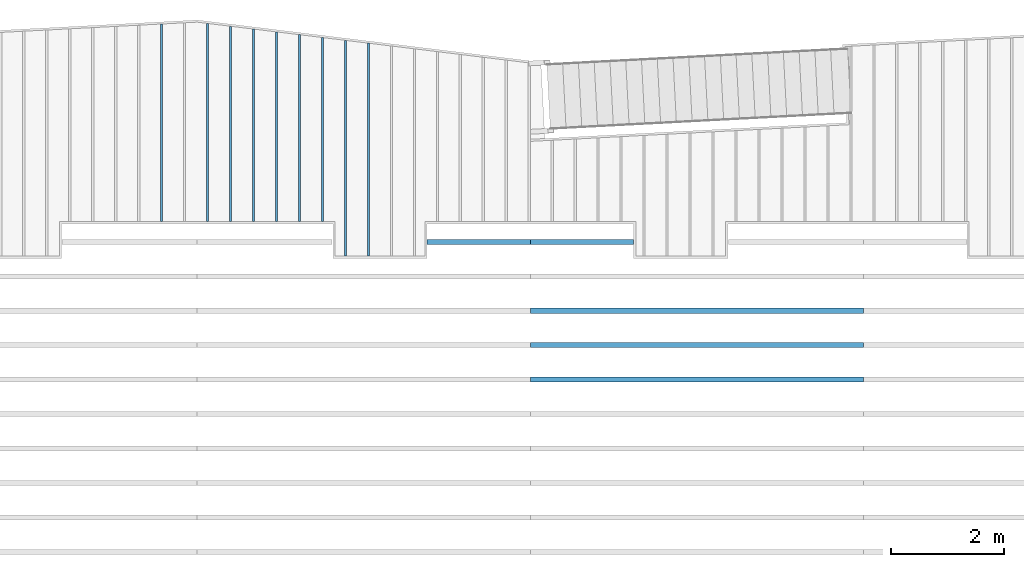
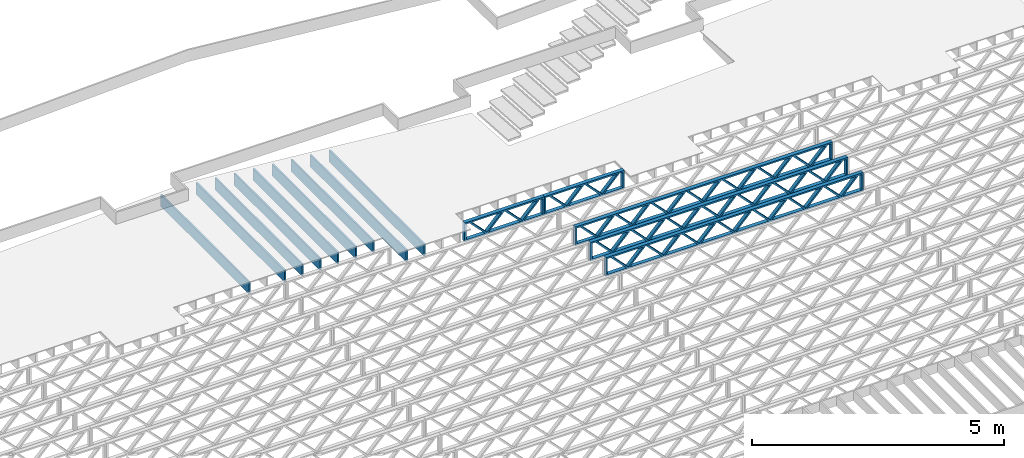
# One storey, part 9 of 23: 14 beams, 3 elements without a shape of their own.
"""IFC4 building model written with IfcOpenShell, lengths in feet."""

from ifc_helpers import new_model, entity, si_unit, converted_unit, derived_unit, direction, frame, frame_2d, origin, origin_2d_with_axis, place, context, subcontext, project, spatial, rectangle, extrude, source, transform, mapped, material, material_profile, profile_set, profile_usage, type_object, type_shapes, element, aggregate, save


model = new_model("IFC4")

# Units and contexts
model_context_1 = context("Model", 3, precision=0.0001, world=origin(), true_north=direction((6.12303176911189e-17, 1.0)))
model_context_2 = context("Model", 3, precision=0.0001, world=origin(), true_north=direction((6.12303176911189e-17, 1.0)))
body_context = subcontext(model_context_2, "Body", "Model", "MODEL_VIEW")
ifc_project = project(units=[converted_unit("LENGTHUNIT", "FOOT", entity("IfcRatioMeasure", 0.3048), si_unit("LENGTHUNIT", "METRE"), dimensions=[1, 0, 0, 0, 0, 0, 0]), converted_unit("AREAUNIT", "SQUARE FOOT", entity("IfcRatioMeasure", 0.09290304), si_unit("AREAUNIT", "SQUARE_METRE"), dimensions=[2, 0, 0, 0, 0, 0, 0]), converted_unit("VOLUMEUNIT", "CUBIC FOOT", entity("IfcRatioMeasure", 0.028316846592), si_unit("VOLUMEUNIT", "CUBIC_METRE"), dimensions=[3, 0, 0, 0, 0, 0, 0]), converted_unit("PLANEANGLEUNIT", "DEGREE", entity("IfcRatioMeasure", 0.0174532925199433), si_unit("PLANEANGLEUNIT", "RADIAN"), dimensions=[0, 0, 0, 0, 0, 0, 0]), si_unit("MASSUNIT", "GRAM", prefix="KILO"), derived_unit("MASSDENSITYUNIT", [(si_unit("MASSUNIT", "GRAM", prefix="KILO"), 1), (si_unit("LENGTHUNIT", "METRE"), -3)]), derived_unit("MOMENTOFINERTIAUNIT", [(si_unit("LENGTHUNIT", "METRE"), 4)]), si_unit("TIMEUNIT", "SECOND"), si_unit("FREQUENCYUNIT", "HERTZ"), si_unit("THERMODYNAMICTEMPERATUREUNIT", "DEGREE_CELSIUS"), derived_unit("THERMALTRANSMITTANCEUNIT", [(si_unit("MASSUNIT", "GRAM", prefix="KILO"), 1), (si_unit("THERMODYNAMICTEMPERATUREUNIT", "KELVIN"), -1), (si_unit("TIMEUNIT", "SECOND"), -3)]), derived_unit("VOLUMETRICFLOWRATEUNIT", [(si_unit("LENGTHUNIT", "METRE"), 3), (si_unit("TIMEUNIT", "SECOND"), -1)]), si_unit("ELECTRICCURRENTUNIT", "AMPERE"), si_unit("ELECTRICVOLTAGEUNIT", "VOLT"), si_unit("POWERUNIT", "WATT"), si_unit("FORCEUNIT", "NEWTON"), si_unit("ILLUMINANCEUNIT", "LUX"), si_unit("LUMINOUSFLUXUNIT", "LUMEN"), si_unit("LUMINOUSINTENSITYUNIT", "CANDELA"), derived_unit("USERDEFINED", [(si_unit("MASSUNIT", "GRAM", prefix="KILO"), -1), (si_unit("LENGTHUNIT", "METRE"), -2), (si_unit("TIMEUNIT", "SECOND"), 3), (si_unit("LUMINOUSFLUXUNIT", "LUMEN"), 1)]), derived_unit("LINEARVELOCITYUNIT", [(si_unit("LENGTHUNIT", "METRE"), 1), (si_unit("TIMEUNIT", "SECOND"), -1)]), si_unit("PRESSUREUNIT", "PASCAL"), derived_unit("USERDEFINED", [(si_unit("LENGTHUNIT", "METRE"), -2), (si_unit("MASSUNIT", "GRAM", prefix="KILO"), 1), (si_unit("TIMEUNIT", "SECOND"), -2)]), derived_unit("LINEARFORCEUNIT", [(si_unit("MASSUNIT", "GRAM", prefix="KILO"), 1), (si_unit("LENGTHUNIT", "METRE"), 1), (si_unit("TIMEUNIT", "SECOND"), -2), (si_unit("LENGTHUNIT", "METRE"), -1)]), derived_unit("PLANARFORCEUNIT", [(si_unit("MASSUNIT", "GRAM", prefix="KILO"), 1), (si_unit("LENGTHUNIT", "METRE"), 1), (si_unit("TIMEUNIT", "SECOND"), -2), (si_unit("LENGTHUNIT", "METRE"), -2)])], contexts=[model_context_1])

# Site, building, storey
site_placement = place(None, origin())
site = spatial("IfcSite", under=ifc_project, at=site_placement, CompositionType="ELEMENT")
building_placement = place(site_placement, origin())
building = spatial("IfcBuilding", under=site, at=building_placement, CompositionType="ELEMENT")
storey_placement = place(building_placement, frame((0.0, 0.0, 10.8020833333333)))
storey = spatial("IfcBuildingStorey", under=building, at=storey_placement, Name="2ND FLOOR", CompositionType="ELEMENT", Elevation=10.8020833333333)

# Assembly, beams
assembly_1_placement = place(storey_placement, origin())
assembly_1 = element("IfcElementAssembly", 1, at=assembly_1_placement, inside=storey, Name="Structural Beam System:Structural Framing System", ObjectType="Structural Beam System:Structural Framing System", AssemblyPlace="NOTDEFINED", PredefinedType="BEAM_GRID")
ifc_material_1 = material(Category="Materials")
ifc_material_profile_1 = material_profile(ifc_material_1, rectangle(XDim=0.9375, YDim=0.125000000000011, at=origin_2d_with_axis()))
ifc_profile_set_1 = profile_set([ifc_material_profile_1])
ifc_profile_usage_1 = profile_usage(ifc_profile_set_1, cardinal=8)
beam_type_1 = type_object("IfcBeamType", PredefinedType="BEAM", material=ifc_profile_set_1)
shared_shape_1 = source(origin(), body_context, "Body", "SweptSolid", [
    extrude(rectangle(XDim=0.9375, YDim=0.125000000000011, at=origin_2d_with_axis()), frame((-5.34424013103074, 0.0, 0.0), z_axis=(1.0, 0.0, 0.0), x_axis=(0.0, 0.0, -1.0)), (0.0, 0.0, 1.0), 10.6884802620615),
])
type_shapes(beam_type_1, [shared_shape_1])
beam_1_placement = place(assembly_1_placement, frame((-195.800660485462, 964.372844789321, -0.729166666666744), z_axis=(0.0, 0.0, 1.0), x_axis=(0.0, 1.0, 0.0)))
beam_1 = element("IfcBeam", 2, at=beam_1_placement, type_object=beam_type_1, material=ifc_profile_usage_1, PredefinedType="BEAM", context=body_context, shape_type="MappedRepresentation", body=[
    mapped(shared_shape_1, transform((0.0, 0.0, 0.0), scale=1.0)),
])
ifc_profile_usage_2 = profile_usage(ifc_profile_set_1, cardinal=8)
beam_type_2 = type_object("IfcBeamType", PredefinedType="BEAM", material=ifc_profile_set_1)
shared_shape_2 = source(origin(), body_context, "Body", "SweptSolid", [
    extrude(rectangle(XDim=0.9375, YDim=0.125000000000011, at=origin_2d_with_axis()), frame((-5.58980975533996, 0.0, 0.0), z_axis=(1.0, 0.0, 0.0), x_axis=(0.0, 0.0, -1.0)), (0.0, 0.0, 1.0), 11.1796195106799),
])
type_shapes(beam_type_2, [shared_shape_2])
beam_2_placement = place(assembly_1_placement, frame((-199.800660485462, 964.618413408623, -0.729166666666744), z_axis=(0.0, 0.0, 1.0), x_axis=(0.0, 1.0, 0.0)))
beam_2 = element("IfcBeam", 3, at=beam_2_placement, type_object=beam_type_2, material=ifc_profile_usage_2, PredefinedType="BEAM", context=body_context, shape_type="MappedRepresentation", body=[
    mapped(shared_shape_2, transform((0.0, 0.0, 0.0), scale=1.0)),
])
ifc_profile_usage_3 = profile_usage(ifc_profile_set_1, cardinal=8)
beam_type_3 = type_object("IfcBeamType", PredefinedType="BEAM", material=ifc_profile_set_1)
shared_shape_3 = source(origin(), body_context, "Body", "SweptSolid", [
    extrude(rectangle(XDim=0.9375, YDim=0.125000000000011, at=origin_2d_with_axis()), frame((-5.67166629677644, 0.0, 0.0), z_axis=(1.0, 0.0, 0.0), x_axis=(0.0, 0.0, -1.0)), (0.0, 0.0, 1.0), 11.3433325935529),
])
type_shapes(beam_type_3, [shared_shape_3])
beam_3_placement = place(assembly_1_placement, frame((-201.133993818795, 964.700269615057, -0.729166666666744), z_axis=(0.0, 0.0, 1.0), x_axis=(0.0, 1.0, 0.0)))
beam_3 = element("IfcBeam", 4, at=beam_3_placement, type_object=beam_type_3, material=ifc_profile_usage_3, PredefinedType="BEAM", context=body_context, shape_type="MappedRepresentation", body=[
    mapped(shared_shape_3, transform((0.0, 0.0, 0.0), scale=1.0)),
])

# Assembly, beam
assembly_2_placement = place(storey_placement, origin())
assembly_2 = element("IfcElementAssembly", 5, at=assembly_2_placement, inside=storey, Name="Structural Beam System:Structural Framing System", ObjectType="Structural Beam System:Structural Framing System", AssemblyPlace="NOTDEFINED", PredefinedType="BEAM_GRID")
ifc_material_2 = material(Name="WOOD TRUSS", Category="Materials")
ifc_material_profile_2 = material_profile(ifc_material_2, rectangle(XDim=1.73473973950632, YDim=0.125, at=frame_2d((-1.11022302462516e-16, 8.32667268468867e-17), x_axis=(1.0, 0.0))))
ifc_material_profile_3 = material_profile(ifc_material_2, rectangle(XDim=1.73473973950633, YDim=0.125, at=frame_2d((-1.11022302462516e-16, 8.32667268468867e-17), x_axis=(1.0, 0.0))))
ifc_material_profile_4 = material_profile(ifc_material_2, rectangle(XDim=1.73473973950632, YDim=0.125, at=frame_2d((-5.55111512312578e-17, 1.38777878078145e-16), x_axis=(1.0, 0.0))))
ifc_material_profile_5 = material_profile(ifc_material_2, rectangle(XDim=1.73473973950633, YDim=0.125, at=frame_2d((-1.11022302462516e-16, 8.32667268468867e-17), x_axis=(1.0, 0.0))))
ifc_material_profile_6 = material_profile(ifc_material_2, rectangle(XDim=1.73473973950632, YDim=0.125, at=frame_2d((-1.11022302462516e-16, 8.32667268468867e-17), x_axis=(1.0, 0.0))))
ifc_material_profile_7 = material_profile(ifc_material_2, rectangle(XDim=1.73473973950633, YDim=0.125, at=frame_2d((-2.77555756156289e-16, 3.05311331771918e-16), x_axis=(1.0, 0.0))))
ifc_material_profile_8 = material_profile(ifc_material_2, rectangle(XDim=1.73473973950632, YDim=0.124999999999999, at=frame_2d((-3.88578058618805e-16, -2.4980018054066e-16), x_axis=(1.0, 0.0))))
ifc_material_profile_9 = material_profile(ifc_material_2, rectangle(XDim=1.73473973950633, YDim=0.125, at=frame_2d((2.77555756156289e-16, -3.05311331771918e-16), x_axis=(1.0, 0.0))))
ifc_material_profile_10 = material_profile(ifc_material_2, rectangle(XDim=1.73473973950632, YDim=0.124999999999999, at=frame_2d((-1.11022302462516e-16, 8.32667268468867e-17), x_axis=(1.0, 0.0))))
ifc_material_profile_11 = material_profile(ifc_material_2, rectangle(XDim=1.73473973950633, YDim=0.125, at=origin_2d_with_axis()))
ifc_material_profile_12 = material_profile(ifc_material_2, rectangle(XDim=0.124999999999982, YDim=0.291666666666668, at=origin_2d_with_axis()))
ifc_material_profile_13 = material_profile(ifc_material_2, rectangle(XDim=0.124999999999932, YDim=0.291666666666664, at=origin_2d_with_axis()))
ifc_material_profile_14 = material_profile(ifc_material_2, rectangle(XDim=1.25000000000002, YDim=0.29166666666667, at=origin_2d_with_axis()))
ifc_material_profile_15 = material_profile(ifc_material_2, rectangle(XDim=1.25000000000004, YDim=0.291666666666667, at=origin_2d_with_axis()))
ifc_profile_set_2 = profile_set([ifc_material_profile_2, ifc_material_profile_3, ifc_material_profile_4, ifc_material_profile_5, ifc_material_profile_6, ifc_material_profile_7, ifc_material_profile_8, ifc_material_profile_9, ifc_material_profile_10, ifc_material_profile_11, ifc_material_profile_12, ifc_material_profile_13, ifc_material_profile_14, ifc_material_profile_15])
ifc_profile_usage_4 = profile_usage(ifc_profile_set_2, cardinal=8)
beam_type_4 = type_object("IfcBeamType", PredefinedType="BEAM", material=ifc_profile_set_2)
shared_shape_4 = source(origin(), body_context, "Body", "SweptSolid", [
    extrude(rectangle(XDim=1.73473973950632, YDim=0.125, at=frame_2d((0.0, 1.66533453693773e-16), x_axis=(1.0, 0.0))), frame((1.95847610985504, -0.145833333333334, 0.0), z_axis=(0.0, 1.0, 0.0), x_axis=(0.693383046997606, 0.0, 0.720569184836762)), (0.0, 0.0, 1.0), 0.291666666666667),
    extrude(rectangle(XDim=1.73473973950633, YDim=0.125, at=frame_2d((-5.55111512312578e-17, 8.32667268468867e-17), x_axis=(1.0, 0.0))), frame((0.708190236181772, -0.145833333333334, 0.0), z_axis=(0.0, 1.0, 0.0), x_axis=(0.69338304699761, 0.0, -0.720569184836758)), (0.0, 0.0, 1.0), 0.291666666666667),
    extrude(rectangle(XDim=1.73473973950632, YDim=0.125, at=frame_2d((0.0, 1.66533453693773e-16), x_axis=(1.0, 0.0))), frame((-0.708190236181118, -0.145833333333334, 0.0), z_axis=(0.0, 1.0, 0.0), x_axis=(0.693383046997606, 0.0, 0.720569184836762)), (0.0, 0.0, 1.0), 0.291666666666667),
    extrude(rectangle(XDim=1.73473973950633, YDim=0.125, at=frame_2d((-2.22044604925031e-16, 2.22044604925031e-16), x_axis=(1.0, 0.0))), frame((-1.95847610985439, -0.145833333333334, 0.0), z_axis=(0.0, 1.0, 0.0), x_axis=(0.69338304699761, 0.0, -0.720569184836758)), (0.0, 0.0, 1.0), 0.291666666666666),
    extrude(rectangle(XDim=0.124999999999982, YDim=0.291666666666668, at=origin_2d_with_axis()), frame((-2.99999983968466, 0.0, 0.687500000000054), z_axis=(1.0, 0.0, 0.0), x_axis=(0.0, 0.0, -1.0)), (0.0, 0.0, 1.0), 5.99999967936932),
    extrude(rectangle(XDim=0.124999999999932, YDim=0.291666666666664, at=origin_2d_with_axis()), frame((-2.99999983968445, 0.0, -0.687499999999984), z_axis=(1.0, 0.0, 0.0), x_axis=(0.0, 0.0, -1.0)), (0.0, 0.0, 1.0), 5.99999967936911),
    extrude(rectangle(XDim=1.25000000000002, YDim=0.29166666666667, at=origin_2d_with_axis()), frame((2.87499983968464, 0.0, 0.0), z_axis=(1.0, 0.0, 0.0), x_axis=(0.0, 0.0, -1.0)), (0.0, 0.0, 1.0), 0.12500000000002),
    extrude(rectangle(XDim=1.25000000000004, YDim=0.291666666666667, at=origin_2d_with_axis()), frame((-2.99999983968466, 0.0, 0.0), z_axis=(1.0, 0.0, 0.0), x_axis=(0.0, 0.0, -1.0)), (0.0, 0.0, 1.0), 0.125000000000023),
])
type_shapes(beam_type_4, [shared_shape_4])
beam_4_placement = place(assembly_2_placement, frame((-186.738160325248, 957.861934882651, -0.947916666666872)))
beam_4 = element("IfcBeam", 6, at=beam_4_placement, type_object=beam_type_4, material=ifc_profile_usage_4, PredefinedType="BEAM", context=body_context, shape_type="MappedRepresentation", body=[
    mapped(shared_shape_4, transform((0.0, 0.0, 0.0), scale=1.0)),
])
aggregate(assembly_2, [beam_4])

# Assembly, beams
assembly_3_placement = place(storey_placement, origin())
assembly_3 = element("IfcElementAssembly", 7, at=assembly_3_placement, inside=storey, Name="Structural Beam System:Structural Framing System", ObjectType="Structural Beam System:Structural Framing System", AssemblyPlace="NOTDEFINED", PredefinedType="BEAM_GRID")
ifc_profile_usage_5 = profile_usage(ifc_profile_set_2, cardinal=8)
beam_type_5 = type_object("IfcBeamType", PredefinedType="BEAM", material=ifc_profile_set_2)
shared_shape_5 = source(origin(), body_context, "Body", "SweptSolid", [
    extrude(rectangle(XDim=1.73473973950632, YDim=0.124999999999999, at=frame_2d((5.55111512312578e-16, 7.21644966006352e-16), x_axis=(1.0, 0.0))), frame((5.95847627016997, -0.145833333333334, 0.0), z_axis=(0.0, 1.0, 0.0), x_axis=(0.693383046997606, 0.0, 0.720569184836762)), (0.0, 0.0, 1.0), 0.291666666666667),
    extrude(rectangle(XDim=1.73473973950633, YDim=0.125, at=origin_2d_with_axis()), frame((4.7081903964967, -0.145833333333334, 0.0), z_axis=(0.0, 1.0, 0.0), x_axis=(0.69338304699761, 0.0, -0.720569184836758)), (0.0, 0.0, 1.0), 0.291666666666666),
    extrude(rectangle(XDim=1.73473973950632, YDim=0.125, at=frame_2d((2.22044604925031e-16, 3.88578058618805e-16), x_axis=(1.0, 0.0))), frame((3.29180960350347, -0.145833333333334, 0.0), z_axis=(0.0, 1.0, 0.0), x_axis=(0.693383046997606, 0.0, 0.720569184836762)), (0.0, 0.0, 1.0), 0.291666666666667),
    extrude(rectangle(XDim=1.73473973950633, YDim=0.125, at=frame_2d((1.11022302462516e-16, -8.32667268468867e-17), x_axis=(1.0, 0.0))), frame((2.0415237298302, -0.145833333333334, 0.0), z_axis=(0.0, 1.0, 0.0), x_axis=(0.69338304699761, 0.0, -0.720569184836758)), (0.0, 0.0, 1.0), 0.291666666666667),
    extrude(rectangle(XDim=1.73473973950632, YDim=0.125, at=frame_2d((-5.55111512312578e-17, 1.38777878078145e-16), x_axis=(1.0, 0.0))), frame((0.625142936836964, -0.145833333333334, 0.0), z_axis=(0.0, 1.0, 0.0), x_axis=(0.693383046997606, 0.0, 0.720569184836762)), (0.0, 0.0, 1.0), 0.291666666666667),
    extrude(rectangle(XDim=1.73473973950633, YDim=0.125, at=frame_2d((-1.11022302462516e-16, 8.32667268468867e-17), x_axis=(1.0, 0.0))), frame((-0.625142936836306, -0.145833333333334, 0.0), z_axis=(0.0, 1.0, 0.0), x_axis=(0.69338304699761, 0.0, -0.720569184836758)), (0.0, 0.0, 1.0), 0.291666666666667),
    extrude(rectangle(XDim=1.73473973950632, YDim=0.125, at=frame_2d((-1.11022302462516e-16, 8.32667268468867e-17), x_axis=(1.0, 0.0))), frame((-2.04152372982954, -0.145833333333334, 0.0), z_axis=(0.0, 1.0, 0.0), x_axis=(0.693383046997606, 0.0, 0.720569184836762)), (0.0, 0.0, 1.0), 0.291666666666667),
    extrude(rectangle(XDim=1.73473973950633, YDim=0.125, at=origin_2d_with_axis()), frame((-3.29180960350281, -0.145833333333334, 0.0), z_axis=(0.0, 1.0, 0.0), x_axis=(0.69338304699761, 0.0, -0.720569184836758)), (0.0, 0.0, 1.0), 0.291666666666667),
    extrude(rectangle(XDim=1.73473973950632, YDim=0.124999999999999, at=frame_2d((-1.11022302462516e-16, 8.32667268468867e-17), x_axis=(1.0, 0.0))), frame((-4.70819039649604, -0.145833333333334, 0.0), z_axis=(0.0, 1.0, 0.0), x_axis=(0.693383046997606, 0.0, 0.720569184836762)), (0.0, 0.0, 1.0), 0.291666666666667),
    extrude(rectangle(XDim=1.73473973950633, YDim=0.125, at=frame_2d((-5.55111512312578e-16, 6.38378239159465e-16), x_axis=(1.0, 0.0))), frame((-5.95847627016931, -0.145833333333334, 0.0), z_axis=(0.0, 1.0, 0.0), x_axis=(0.69338304699761, 0.0, -0.720569184836758)), (0.0, 0.0, 1.0), 0.291666666666666),
    extrude(rectangle(XDim=1.73473973950632, YDim=0.125, at=frame_2d((-7.21644966006352e-16, -5.82867087928207e-16), x_axis=(1.0, 0.0))), frame((8.62514293683647, -0.145833333333334, 0.0), z_axis=(0.0, 1.0, 0.0), x_axis=(0.693383046997607, 0.0, 0.720569184836761)), (0.0, 0.0, 1.0), 0.291666666666667),
    extrude(rectangle(XDim=1.73473973950633, YDim=0.125, at=origin_2d_with_axis()), frame((7.3748570631632, -0.145833333333334, 0.0), z_axis=(0.0, 1.0, 0.0), x_axis=(0.69338304699761, 0.0, -0.720569184836758)), (0.0, 0.0, 1.0), 0.291666666666666),
    extrude(rectangle(XDim=1.73473973950632, YDim=0.124999999999999, at=frame_2d((-1.11022302462516e-16, 8.32667268468867e-17), x_axis=(1.0, 0.0))), frame((-7.37485706316255, -0.145833333333334, 0.0), z_axis=(0.0, 1.0, 0.0), x_axis=(0.693383046997606, 0.0, 0.720569184836762)), (0.0, 0.0, 1.0), 0.291666666666667),
    extrude(rectangle(XDim=1.73473973950633, YDim=0.125, at=origin_2d_with_axis()), frame((-8.62514293683582, -0.145833333333334, 0.0), z_axis=(0.0, 1.0, 0.0), x_axis=(0.69338304699761, 0.0, -0.720569184836758)), (0.0, 0.0, 1.0), 0.291666666666666),
    extrude(rectangle(XDim=0.124999999999982, YDim=0.291666666666668, at=origin_2d_with_axis()), frame((-9.66666666666609, 0.0, 0.687500000000054), z_axis=(1.0, 0.0, 0.0), x_axis=(0.0, 0.0, -1.0)), (0.0, 0.0, 1.0), 19.3333333333322),
    extrude(rectangle(XDim=0.124999999999932, YDim=0.291666666666664, at=origin_2d_with_axis()), frame((-9.66666666666588, 0.0, -0.687499999999984), z_axis=(1.0, 0.0, 0.0), x_axis=(0.0, 0.0, -1.0)), (0.0, 0.0, 1.0), 19.333333333332),
    extrude(rectangle(XDim=1.25000000000002, YDim=0.29166666666667, at=origin_2d_with_axis()), frame((9.54166666666607, 0.0, 0.0), z_axis=(1.0, 0.0, 0.0), x_axis=(0.0, 0.0, -1.0)), (0.0, 0.0, 1.0), 0.12500000000002),
    extrude(rectangle(XDim=1.25000000000004, YDim=0.291666666666667, at=origin_2d_with_axis()), frame((-9.66666666666609, 0.0, 0.0), z_axis=(1.0, 0.0, 0.0), x_axis=(0.0, 0.0, -1.0)), (0.0, 0.0, 1.0), 0.125000000000023),
])
type_shapes(beam_type_5, [shared_shape_5])
beam_5_placement = place(assembly_3_placement, frame((-174.071493818896, 953.861934882651, -0.947916666666657), z_axis=(0.0, 0.0, 1.0), x_axis=(-1.0, 0.0, 0.0)))
beam_5 = element("IfcBeam", 8, at=beam_5_placement, type_object=beam_type_5, material=ifc_profile_usage_5, PredefinedType="BEAM", context=body_context, shape_type="MappedRepresentation", body=[
    mapped(shared_shape_5, transform((0.0, 0.0, 0.0), scale=1.0)),
])
ifc_profile_usage_6 = profile_usage(ifc_profile_set_2, cardinal=8)
beam_6_placement = place(assembly_3_placement, frame((-174.071493818896, 951.861934882651, -0.947916666666657), z_axis=(0.0, 0.0, 1.0), x_axis=(-1.0, 0.0, 0.0)))
beam_6 = element("IfcBeam", 9, at=beam_6_placement, type_object=beam_type_5, material=ifc_profile_usage_6, PredefinedType="BEAM", context=body_context, shape_type="MappedRepresentation", body=[
    mapped(shared_shape_5, transform((0.0, 0.0, 0.0), scale=1.0)),
])
ifc_profile_usage_7 = profile_usage(ifc_profile_set_2, cardinal=8)
beam_7_placement = place(assembly_3_placement, frame((-174.071493818896, 949.861934882651, -0.947916666666657), z_axis=(0.0, 0.0, 1.0), x_axis=(-1.0, 0.0, 0.0)))
beam_7 = element("IfcBeam", 10, at=beam_7_placement, type_object=beam_type_5, material=ifc_profile_usage_7, PredefinedType="BEAM", context=body_context, shape_type="MappedRepresentation", body=[
    mapped(shared_shape_5, transform((0.0, 0.0, 0.0), scale=1.0)),
])

# Beam
ifc_profile_usage_8 = profile_usage(ifc_profile_set_1, cardinal=8)
beam_type_6 = type_object("IfcBeamType", PredefinedType="BEAM", material=ifc_profile_set_1)
shared_shape_6 = source(origin(), body_context, "Body", "SweptSolid", [
    extrude(rectangle(XDim=0.9375, YDim=0.125000000000011, at=origin_2d_with_axis()), frame((-5.7535228382128, 0.0, 0.0), z_axis=(1.0, 0.0, 0.0), x_axis=(0.0, 0.0, -1.0)), (0.0, 0.0, 1.0), 11.5070456764256),
])
type_shapes(beam_type_6, [shared_shape_6])
beam_8_placement = place(assembly_1_placement, frame((-202.467327152129, 964.782125821491, -0.729166666666744), z_axis=(0.0, 0.0, 1.0), x_axis=(0.0, 1.0, 0.0)))
beam_8 = element("IfcBeam", 11, at=beam_8_placement, type_object=beam_type_6, material=ifc_profile_usage_8, PredefinedType="BEAM", context=body_context, shape_type="MappedRepresentation", body=[
    mapped(shared_shape_6, transform((0.0, 0.0, 0.0), scale=1.0)),
])

ifc_profile_usage_9 = profile_usage(ifc_profile_set_1, cardinal=8)
beam_type_7 = type_object("IfcBeamType", PredefinedType="BEAM", material=ifc_profile_set_1)
shared_shape_7 = source(origin(), body_context, "Body", "SweptSolid", [
    extrude(rectangle(XDim=0.9375, YDim=0.125000000000011, at=origin_2d_with_axis()), frame((-5.73574080597081, 0.0, 0.0), z_axis=(1.0, 0.0, 0.0), x_axis=(0.0, 0.0, -1.0)), (0.0, 0.0, 1.0), 11.4714816119416),
])
type_shapes(beam_type_7, [shared_shape_7])
beam_9_placement = place(assembly_1_placement, frame((-205.133993818795, 964.764343119245, -0.729166666666744), z_axis=(0.0, 0.0, 1.0), x_axis=(0.0, 1.0, 0.0)))
beam_9 = element("IfcBeam", 12, at=beam_9_placement, type_object=beam_type_7, material=ifc_profile_usage_9, PredefinedType="BEAM", context=body_context, shape_type="MappedRepresentation", body=[
    mapped(shared_shape_7, transform((0.0, 0.0, 0.0), scale=1.0)),
])

ifc_profile_usage_10 = profile_usage(ifc_profile_set_1, cardinal=8)
beam_type_8 = type_object("IfcBeamType", PredefinedType="BEAM", material=ifc_profile_set_1)
shared_shape_8 = source(origin(), body_context, "Body", "SweptSolid", [
    extrude(rectangle(XDim=0.9375, YDim=0.125000000000011, at=origin_2d_with_axis()), frame((-5.50795321390359, 0.0, 0.0), z_axis=(1.0, 0.0, 0.0), x_axis=(0.0, 0.0, -1.0)), (0.0, 0.0, 1.0), 11.0159064278072),
])
type_shapes(beam_type_8, [shared_shape_8])
beam_10_placement = place(assembly_1_placement, frame((-198.467327152129, 964.536557202189, -0.729166666666744), z_axis=(0.0, 0.0, 1.0), x_axis=(0.0, 1.0, 0.0)))
beam_10 = element("IfcBeam", 13, at=beam_10_placement, type_object=beam_type_8, material=ifc_profile_usage_10, PredefinedType="BEAM", context=body_context, shape_type="MappedRepresentation", body=[
    mapped(shared_shape_8, transform((0.0, 0.0, 0.0), scale=1.0)),
])

ifc_profile_usage_11 = profile_usage(ifc_profile_set_1, cardinal=8)
beam_type_9 = type_object("IfcBeamType", PredefinedType="BEAM", material=ifc_profile_set_1)
shared_shape_9 = source(origin(), body_context, "Body", "SweptSolid", [
    extrude(rectangle(XDim=0.9375, YDim=0.125000000000011, at=origin_2d_with_axis()), frame((-5.42609667246711, 0.0, 0.0), z_axis=(1.0, 0.0, 0.0), x_axis=(0.0, 0.0, -1.0)), (0.0, 0.0, 1.0), 10.8521933449342),
])
type_shapes(beam_type_9, [shared_shape_9])
beam_11_placement = place(assembly_1_placement, frame((-197.133993818795, 964.454700995755, -0.729166666666744), z_axis=(0.0, 0.0, 1.0), x_axis=(0.0, 1.0, 0.0)))
beam_11 = element("IfcBeam", 14, at=beam_11_placement, type_object=beam_type_9, material=ifc_profile_usage_11, PredefinedType="BEAM", context=body_context, shape_type="MappedRepresentation", body=[
    mapped(shared_shape_9, transform((0.0, 0.0, 0.0), scale=1.0)),
])

ifc_profile_usage_12 = profile_usage(ifc_profile_set_1, cardinal=8)
beam_type_10 = type_object("IfcBeamType", PredefinedType="BEAM", material=ifc_profile_set_1)
shared_shape_10 = source(origin(), body_context, "Body", "SweptSolid", [
    extrude(rectangle(XDim=0.9375, YDim=0.125000000000011, at=origin_2d_with_axis()), frame((-6.26238531158162, 0.0, 0.0), z_axis=(1.0, 0.0, 0.0), x_axis=(0.0, 0.0, -1.0)), (0.0, 0.0, 1.0), 12.5247706231632),
])
type_shapes(beam_type_10, [shared_shape_10])
beam_12_placement = place(assembly_1_placement, frame((-194.467327152129, 963.290986860899, -0.729166666666744), z_axis=(0.0, 0.0, 1.0), x_axis=(0.0, 1.0, 0.0)))
beam_12 = element("IfcBeam", 15, at=beam_12_placement, type_object=beam_type_10, material=ifc_profile_usage_12, PredefinedType="BEAM", context=body_context, shape_type="MappedRepresentation", body=[
    mapped(shared_shape_10, transform((0.0, 0.0, 0.0), scale=1.0)),
])

ifc_profile_usage_13 = profile_usage(ifc_profile_set_1, cardinal=8)
beam_type_11 = type_object("IfcBeamType", PredefinedType="BEAM", material=ifc_profile_set_1)
shared_shape_11 = source(origin(), body_context, "Body", "SweptSolid", [
    extrude(rectangle(XDim=0.9375, YDim=0.125000000000011, at=origin_2d_with_axis()), frame((-6.18052893764639, 0.0, 0.0), z_axis=(1.0, 0.0, 0.0), x_axis=(0.0, 0.0, -1.0)), (0.0, 0.0, 1.0), 12.3610578752928),
])
type_shapes(beam_type_11, [shared_shape_11])
beam_13_placement = place(assembly_1_placement, frame((-193.133993818795, 963.209130486964, -0.729166666666744), z_axis=(0.0, 0.0, 1.0), x_axis=(0.0, 1.0, 0.0)))
beam_13 = element("IfcBeam", 16, at=beam_13_placement, type_object=beam_type_11, material=ifc_profile_usage_13, PredefinedType="BEAM", context=body_context, shape_type="MappedRepresentation", body=[
    mapped(shared_shape_11, transform((0.0, 0.0, 0.0), scale=1.0)),
])

aggregate(assembly_1, [beam_1, beam_2, beam_3, beam_8, beam_9, beam_10, beam_11, beam_12, beam_13])

ifc_profile_usage_14 = profile_usage(ifc_profile_set_2, cardinal=8)
beam_type_12 = type_object("IfcBeamType", PredefinedType="BEAM", material=ifc_profile_set_2)
shared_shape_12 = source(origin(), body_context, "Body", "SweptSolid", [
    extrude(rectangle(XDim=1.73473973950632, YDim=0.125, at=frame_2d((0.0, 1.66533453693773e-16), x_axis=(1.0, 0.0))), frame((1.95847612494153, -0.145833333333334, 0.0), z_axis=(0.0, 1.0, 0.0), x_axis=(0.693383046997606, 0.0, 0.720569184836762)), (0.0, 0.0, 1.0), 0.291666666666667),
    extrude(rectangle(XDim=1.73473973950633, YDim=0.125, at=frame_2d((-5.55111512312578e-17, 8.32667268468867e-17), x_axis=(1.0, 0.0))), frame((0.708190251268258, -0.145833333333334, 0.0), z_axis=(0.0, 1.0, 0.0), x_axis=(0.69338304699761, 0.0, -0.720569184836758)), (0.0, 0.0, 1.0), 0.291666666666667),
    extrude(rectangle(XDim=1.73473973950632, YDim=0.125, at=frame_2d((0.0, 1.66533453693773e-16), x_axis=(1.0, 0.0))), frame((-0.708190251267602, -0.145833333333334, 0.0), z_axis=(0.0, 1.0, 0.0), x_axis=(0.693383046997606, 0.0, 0.720569184836762)), (0.0, 0.0, 1.0), 0.291666666666667),
    extrude(rectangle(XDim=1.73473973950633, YDim=0.125, at=frame_2d((-2.22044604925031e-16, 2.22044604925031e-16), x_axis=(1.0, 0.0))), frame((-1.95847612494087, -0.145833333333334, 0.0), z_axis=(0.0, 1.0, 0.0), x_axis=(0.69338304699761, 0.0, -0.720569184836758)), (0.0, 0.0, 1.0), 0.291666666666666),
    extrude(rectangle(XDim=0.124999999999982, YDim=0.291666666666668, at=origin_2d_with_axis()), frame((-2.99999985477115, 0.0, 0.687500000000054), z_axis=(1.0, 0.0, 0.0), x_axis=(0.0, 0.0, -1.0)), (0.0, 0.0, 1.0), 5.99999970954229),
    extrude(rectangle(XDim=0.124999999999932, YDim=0.291666666666664, at=origin_2d_with_axis()), frame((-2.99999985477093, 0.0, -0.687499999999984), z_axis=(1.0, 0.0, 0.0), x_axis=(0.0, 0.0, -1.0)), (0.0, 0.0, 1.0), 5.99999970954208),
    extrude(rectangle(XDim=1.25000000000002, YDim=0.29166666666667, at=origin_2d_with_axis()), frame((2.87499985477113, 0.0, 0.0), z_axis=(1.0, 0.0, 0.0), x_axis=(0.0, 0.0, -1.0)), (0.0, 0.0, 1.0), 0.12500000000002),
    extrude(rectangle(XDim=1.25000000000004, YDim=0.291666666666667, at=origin_2d_with_axis()), frame((-2.99999985477115, 0.0, 0.0), z_axis=(1.0, 0.0, 0.0), x_axis=(0.0, 0.0, -1.0)), (0.0, 0.0, 1.0), 0.125000000000023),
])
type_shapes(beam_type_12, [shared_shape_12])
beam_14_placement = place(assembly_3_placement, frame((-180.738160630791, 957.861934882651, -0.947916666666648), z_axis=(0.0, 0.0, 1.0), x_axis=(-1.0, 0.0, 0.0)))
beam_14 = element("IfcBeam", 17, at=beam_14_placement, type_object=beam_type_12, material=ifc_profile_usage_14, PredefinedType="BEAM", context=body_context, shape_type="MappedRepresentation", body=[
    mapped(shared_shape_12, transform((0.0, 0.0, 0.0), scale=1.0)),
])

aggregate(assembly_3, [beam_5, beam_6, beam_7, beam_14])

save(model, "model.ifc")
